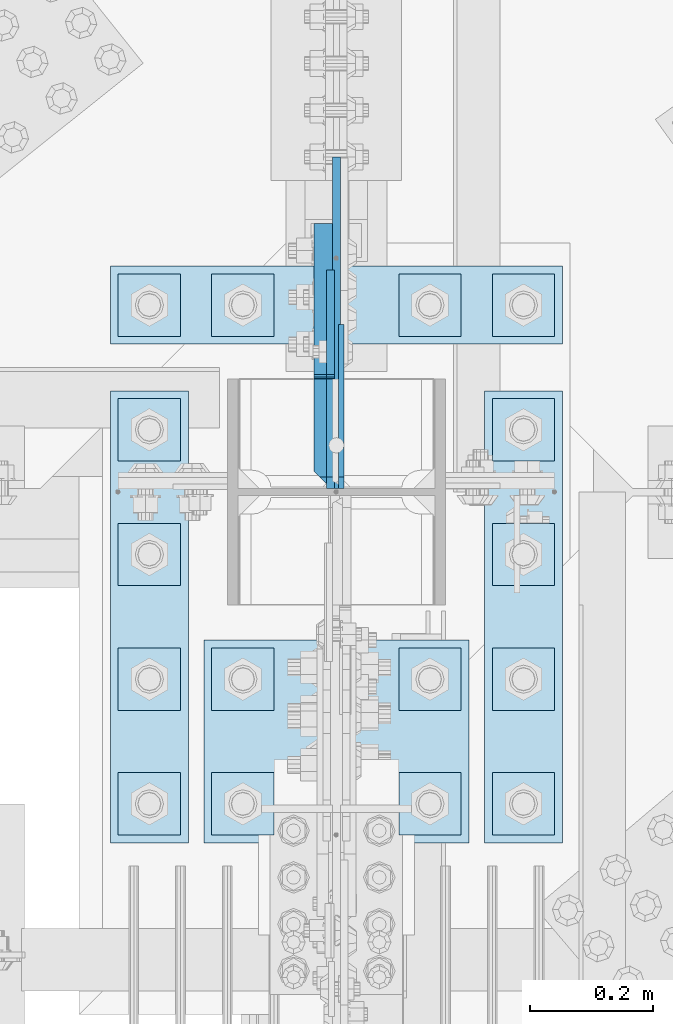
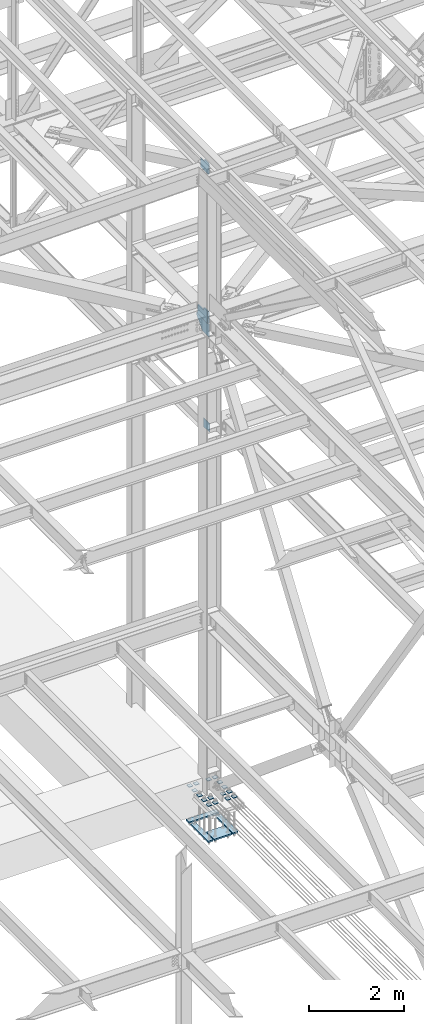
# One storey, part 3201 of 3843: 24 plates, 2 elements without a shape of their own.
"""IFC2X3 building model written with IfcOpenShell, lengths in millimetres."""

from ifc_helpers import new_model, si_unit, frame, origin_with_axes, place, context, subcontext, project, spatial, faceted_brep, material, type_object, element, aggregate, save


model = new_model("IFC2X3")

# Units and contexts
model_context = context("Model", 3, precision=1e-05, world=origin_with_axes())
body_context = subcontext(model_context, "Body", "Model", "MODEL_VIEW")
ifc_project = project(units=[si_unit("LENGTHUNIT", "METRE", prefix="MILLI"), si_unit("AREAUNIT", "SQUARE_METRE"), si_unit("VOLUMEUNIT", "CUBIC_METRE"), si_unit("MASSUNIT", "GRAM", prefix="KILO"), si_unit("TIMEUNIT", "SECOND"), si_unit("PLANEANGLEUNIT", "RADIAN"), si_unit("SOLIDANGLEUNIT", "STERADIAN"), si_unit("THERMODYNAMICTEMPERATUREUNIT", "DEGREE_CELSIUS"), si_unit("LUMINOUSINTENSITYUNIT", "LUMEN")], contexts=[model_context])

# Site, building, storey
site_placement = place(None, origin_with_axes())
site = spatial("IfcSite", under=ifc_project, at=site_placement, CompositionType="ELEMENT")
building_placement = place(site_placement, origin_with_axes())
building = spatial("IfcBuilding", under=site, at=building_placement, Name="Undefined", CompositionType="ELEMENT")
storey_placement = place(building_placement, origin_with_axes())
storey = spatial("IfcBuildingStorey", under=building, at=storey_placement, Name="Undefined", CompositionType="ELEMENT", Elevation=0.0)

# Assembly, plate
assembly_1_placement = place(storey_placement, origin_with_axes())
assembly_1 = element("IfcElementAssembly", 1, at=assembly_1_placement, inside=storey, Name="COLUMN", AssemblyPlace="NOTDEFINED", PredefinedType="RIGID_FRAME")
ifc_material = material(Name="STEEL/A572-50")
plate_type_1 = type_object("IfcPlateType", PredefinedType="NOTDEFINED")
plate_1_placement = place(assembly_1_placement, frame((77020.7375, 25621.45625, 39331.9), z_axis=(0.0, 0.707106781186548, 0.707106781186548), x_axis=(5.70000238222118e-08, 0.707106781186546, -0.707106781186546)))
plate_1 = element("IfcPlate", 2, at=plate_1_placement, type_object=plate_type_1, material=ifc_material, Name="PLATE", context=body_context, shape_type="Brep", body=[
    faceted_brep([(0.0, -4.76249999999709, 0.0), (-134.703841815408, -4.76249999999709, 134.703841815382), (-134.703841815408, 4.76249999999709, 134.703841815382), (0.0, 4.76249999999709, 0.0), (-134.703841815266, -4.76249999999709, 161.644610178599), (-134.703841815266, 4.76249999999709, 161.644610178599), (40.9724185541018, -4.76249999999709, 337.320870548006), (40.9724185541018, 4.76249999999709, 337.320870548006), (202.617028732588, -4.76249999999709, 175.676260369546), (202.617028732588, 4.76249999999709, 175.676260369546), (26.9407683631998, -4.76249999999709, 1.30967237055302e-10), (26.9407683631998, 4.76249999999709, 1.30967237055302e-10)], [[[0, 1, 2, 3]], [[1, 4, 5, 2]], [[4, 6, 7, 5]], [[6, 8, 9, 7]], [[8, 10, 11, 9]], [[10, 0, 3, 11]], [[5, 7, 9, 11, 3, 2]], [[10, 8, 6, 4, 1, 0]]]),
])

# Assembly, plates
assembly_2_placement = place(storey_placement, origin_with_axes())
assembly_2 = element("IfcElementAssembly", 3, at=assembly_2_placement, inside=storey, Name="TEMPLATE", AssemblyPlace="NOTDEFINED", PredefinedType="RIGID_FRAME")
plate_type_2 = type_object("IfcPlateType", PredefinedType="NOTDEFINED")
plate_2_placement = place(assembly_2_placement, frame((77266.8, 25158.7, 30143.45), z_axis=(0.0, -1.0, 0.0), x_axis=(1.0, 0.0, 0.0)))
plate_2 = element("IfcPlate", 4, at=plate_2_placement, type_object=plate_type_2, material=ifc_material, Name="Washer Plate", context=body_context, shape_type="Brep", body=[
    faceted_brep([(0.0, -6.3499999046162, 0.0), (-1.67347025126219e-10, -6.35000000000582, 101.600000000151), (-1.67347025126219e-10, 6.35000000000582, 101.600000000151), (7.27595761418343e-12, 6.3499999046162, 0.0), (101.599998474121, -6.34999999999854, 101.599998474121), (101.599998474121, 6.34999999999854, 101.599998474121), (101.6, -6.34999999999854, 0.0), (101.6, 6.34999999999854, 0.0)], [[[0, 1, 2, 3]], [[1, 4, 5, 2]], [[4, 6, 7, 5]], [[6, 0, 3, 7]], [[5, 7, 3, 2]], [[6, 4, 1, 0]]]),
])
plate_3_placement = place(assembly_2_placement, frame((77266.8, 25361.9, 30143.45), z_axis=(0.0, -1.0, 0.0), x_axis=(1.0, 0.0, 0.0)))
plate_3 = element("IfcPlate", 5, at=plate_3_placement, type_object=plate_type_2, material=ifc_material, Name="Washer Plate", context=body_context, shape_type="Brep", body=[
    faceted_brep([(0.0, -6.3499999046162, 0.0), (-1.67347025126219e-10, -6.35000000000582, 101.600000000151), (-1.67347025126219e-10, 6.35000000000582, 101.600000000151), (7.27595761418343e-12, 6.3499999046162, 0.0), (101.599998474121, -6.34999999999854, 101.599998474121), (101.599998474121, 6.34999999999854, 101.599998474121), (101.6, -6.34999999999854, 0.0), (101.6, 6.34999999999854, 0.0)], [[[0, 1, 2, 3]], [[1, 4, 5, 2]], [[4, 6, 7, 5]], [[6, 0, 3, 7]], [[5, 7, 3, 2]], [[6, 4, 1, 0]]]),
])
plate_4_placement = place(assembly_2_placement, frame((77266.8, 25565.1, 30143.45), z_axis=(0.0, -1.0, 0.0), x_axis=(1.0, 0.0, 0.0)))
plate_4 = element("IfcPlate", 6, at=plate_4_placement, type_object=plate_type_2, material=ifc_material, Name="Washer Plate", context=body_context, shape_type="Brep", body=[
    faceted_brep([(0.0, -6.3499999046162, 0.0), (-1.67347025126219e-10, -6.35000000000582, 101.600000000151), (-1.67347025126219e-10, 6.35000000000582, 101.600000000151), (7.27595761418343e-12, 6.3499999046162, 0.0), (101.599998474121, -6.34999999999854, 101.599998474121), (101.599998474121, 6.34999999999854, 101.599998474121), (101.6, -6.34999999999854, 0.0), (101.6, 6.34999999999854, 0.0)], [[[0, 1, 2, 3]], [[1, 4, 5, 2]], [[4, 6, 7, 5]], [[6, 0, 3, 7]], [[5, 7, 3, 2]], [[6, 4, 1, 0]]]),
])
plate_5_placement = place(assembly_2_placement, frame((77266.8, 25768.3, 30143.45), z_axis=(0.0, -1.0, 0.0), x_axis=(1.0, 0.0, 0.0)))
plate_5 = element("IfcPlate", 7, at=plate_5_placement, type_object=plate_type_2, material=ifc_material, Name="Washer Plate", context=body_context, shape_type="Brep", body=[
    faceted_brep([(0.0, -6.3499999046162, 0.0), (-1.67347025126219e-10, -6.35000000000582, 101.600000000151), (-1.67347025126219e-10, 6.35000000000582, 101.600000000151), (7.27595761418343e-12, 6.3499999046162, 0.0), (101.599998474121, -6.34999999999854, 101.599998474121), (101.599998474121, 6.34999999999854, 101.599998474121), (101.6, -6.34999999999854, 0.0), (101.6, 6.34999999999854, 0.0)], [[[0, 1, 2, 3]], [[1, 4, 5, 2]], [[4, 6, 7, 5]], [[6, 0, 3, 7]], [[5, 7, 3, 2]], [[6, 4, 1, 0]]]),
])
plate_6_placement = place(assembly_2_placement, frame((77266.8, 25971.5, 30143.45), z_axis=(0.0, -1.0, 0.0), x_axis=(1.0, 0.0, 0.0)))
plate_6 = element("IfcPlate", 8, at=plate_6_placement, type_object=plate_type_2, material=ifc_material, Name="Washer Plate", context=body_context, shape_type="Brep", body=[
    faceted_brep([(0.0, -6.3499999046162, 0.0), (-1.67347025126219e-10, -6.35000000000582, 101.600000000151), (-1.67347025126219e-10, 6.35000000000582, 101.600000000151), (7.27595761418343e-12, 6.3499999046162, 0.0), (101.599998474121, -6.34999999999854, 101.599998474121), (101.599998474121, 6.34999999999854, 101.599998474121), (101.6, -6.34999999999854, 0.0), (101.6, 6.34999999999854, 0.0)], [[[0, 1, 2, 3]], [[1, 4, 5, 2]], [[4, 6, 7, 5]], [[6, 0, 3, 7]], [[5, 7, 3, 2]], [[6, 4, 1, 0]]]),
])
plate_7_placement = place(assembly_2_placement, frame((77114.4, 25158.7, 30143.45), z_axis=(0.0, -1.0, 0.0), x_axis=(1.0, 0.0, 0.0)))
plate_7 = element("IfcPlate", 9, at=plate_7_placement, type_object=plate_type_2, material=ifc_material, Name="Washer Plate", context=body_context, shape_type="Brep", body=[
    faceted_brep([(0.0, -6.3499999046162, 0.0), (-1.67347025126219e-10, -6.35000000000582, 101.600000000151), (-1.67347025126219e-10, 6.35000000000582, 101.600000000151), (7.27595761418343e-12, 6.3499999046162, 0.0), (101.599998474121, -6.34999999999854, 101.599998474121), (101.599998474121, 6.34999999999854, 101.599998474121), (101.6, -6.34999999999854, 0.0), (101.6, 6.34999999999854, 0.0)], [[[0, 1, 2, 3]], [[1, 4, 5, 2]], [[4, 6, 7, 5]], [[6, 0, 3, 7]], [[5, 7, 3, 2]], [[6, 4, 1, 0]]]),
])
plate_8_placement = place(assembly_2_placement, frame((77114.4, 25361.9, 30143.45), z_axis=(0.0, -1.0, 0.0), x_axis=(1.0, 0.0, 0.0)))
plate_8 = element("IfcPlate", 10, at=plate_8_placement, type_object=plate_type_2, material=ifc_material, Name="Washer Plate", context=body_context, shape_type="Brep", body=[
    faceted_brep([(0.0, -6.3499999046162, 0.0), (-1.67347025126219e-10, -6.35000000000582, 101.600000000151), (-1.67347025126219e-10, 6.35000000000582, 101.600000000151), (7.27595761418343e-12, 6.3499999046162, 0.0), (101.599998474121, -6.34999999999854, 101.599998474121), (101.599998474121, 6.34999999999854, 101.599998474121), (101.6, -6.34999999999854, 0.0), (101.6, 6.34999999999854, 0.0)], [[[0, 1, 2, 3]], [[1, 4, 5, 2]], [[4, 6, 7, 5]], [[6, 0, 3, 7]], [[5, 7, 3, 2]], [[6, 4, 1, 0]]]),
])
plate_9_placement = place(assembly_2_placement, frame((77114.4, 25971.5, 30143.45), z_axis=(0.0, -1.0, 0.0), x_axis=(1.0, 0.0, 0.0)))
plate_9 = element("IfcPlate", 11, at=plate_9_placement, type_object=plate_type_2, material=ifc_material, Name="Washer Plate", context=body_context, shape_type="Brep", body=[
    faceted_brep([(0.0, -6.3499999046162, 0.0), (-1.67347025126219e-10, -6.35000000000582, 101.600000000151), (-1.67347025126219e-10, 6.35000000000582, 101.600000000151), (7.27595761418343e-12, 6.3499999046162, 0.0), (101.599998474121, -6.34999999999854, 101.599998474121), (101.599998474121, 6.34999999999854, 101.599998474121), (101.6, -6.34999999999854, 0.0), (101.6, 6.34999999999854, 0.0)], [[[0, 1, 2, 3]], [[1, 4, 5, 2]], [[4, 6, 7, 5]], [[6, 0, 3, 7]], [[5, 7, 3, 2]], [[6, 4, 1, 0]]]),
])
plate_10_placement = place(assembly_2_placement, frame((76809.6, 25158.7, 30143.45), z_axis=(0.0, -1.0, 0.0), x_axis=(1.0, 0.0, 0.0)))
plate_10 = element("IfcPlate", 12, at=plate_10_placement, type_object=plate_type_2, material=ifc_material, Name="Washer Plate", context=body_context, shape_type="Brep", body=[
    faceted_brep([(0.0, -6.3499999046162, 0.0), (-1.67347025126219e-10, -6.35000000000582, 101.600000000151), (-1.67347025126219e-10, 6.35000000000582, 101.600000000151), (7.27595761418343e-12, 6.3499999046162, 0.0), (101.599998474121, -6.34999999999854, 101.599998474121), (101.599998474121, 6.34999999999854, 101.599998474121), (101.6, -6.34999999999854, 0.0), (101.6, 6.34999999999854, 0.0)], [[[0, 1, 2, 3]], [[1, 4, 5, 2]], [[4, 6, 7, 5]], [[6, 0, 3, 7]], [[5, 7, 3, 2]], [[6, 4, 1, 0]]]),
])
plate_11_placement = place(assembly_2_placement, frame((76809.6, 25361.9, 30143.45), z_axis=(0.0, -1.0, 0.0), x_axis=(1.0, 0.0, 0.0)))
plate_11 = element("IfcPlate", 13, at=plate_11_placement, type_object=plate_type_2, material=ifc_material, Name="Washer Plate", context=body_context, shape_type="Brep", body=[
    faceted_brep([(0.0, -6.3499999046162, 0.0), (-1.67347025126219e-10, -6.35000000000582, 101.600000000151), (-1.67347025126219e-10, 6.35000000000582, 101.600000000151), (7.27595761418343e-12, 6.3499999046162, 0.0), (101.599998474121, -6.34999999999854, 101.599998474121), (101.599998474121, 6.34999999999854, 101.599998474121), (101.6, -6.34999999999854, 0.0), (101.6, 6.34999999999854, 0.0)], [[[0, 1, 2, 3]], [[1, 4, 5, 2]], [[4, 6, 7, 5]], [[6, 0, 3, 7]], [[5, 7, 3, 2]], [[6, 4, 1, 0]]]),
])
plate_12_placement = place(assembly_2_placement, frame((76809.6, 25971.5, 30143.45), z_axis=(0.0, -1.0, 0.0), x_axis=(1.0, 0.0, 0.0)))
plate_12 = element("IfcPlate", 14, at=plate_12_placement, type_object=plate_type_2, material=ifc_material, Name="Washer Plate", context=body_context, shape_type="Brep", body=[
    faceted_brep([(0.0, -6.3499999046162, 0.0), (-1.67347025126219e-10, -6.35000000000582, 101.600000000151), (-1.67347025126219e-10, 6.35000000000582, 101.600000000151), (7.27595761418343e-12, 6.3499999046162, 0.0), (101.599998474121, -6.34999999999854, 101.599998474121), (101.599998474121, 6.34999999999854, 101.599998474121), (101.6, -6.34999999999854, 0.0), (101.6, 6.34999999999854, 0.0)], [[[0, 1, 2, 3]], [[1, 4, 5, 2]], [[4, 6, 7, 5]], [[6, 0, 3, 7]], [[5, 7, 3, 2]], [[6, 4, 1, 0]]]),
])
plate_13_placement = place(assembly_2_placement, frame((76657.2, 25158.7, 30143.45), z_axis=(0.0, -1.0, 0.0), x_axis=(1.0, 0.0, 0.0)))
plate_13 = element("IfcPlate", 15, at=plate_13_placement, type_object=plate_type_2, material=ifc_material, Name="Washer Plate", context=body_context, shape_type="Brep", body=[
    faceted_brep([(0.0, -6.3499999046162, 0.0), (-1.67347025126219e-10, -6.35000000000582, 101.600000000151), (-1.67347025126219e-10, 6.35000000000582, 101.600000000151), (7.27595761418343e-12, 6.3499999046162, 0.0), (101.599998474121, -6.34999999999854, 101.599998474121), (101.599998474121, 6.34999999999854, 101.599998474121), (101.6, -6.34999999999854, 0.0), (101.6, 6.34999999999854, 0.0)], [[[0, 1, 2, 3]], [[1, 4, 5, 2]], [[4, 6, 7, 5]], [[6, 0, 3, 7]], [[5, 7, 3, 2]], [[6, 4, 1, 0]]]),
])
plate_14_placement = place(assembly_2_placement, frame((76657.2, 25361.9, 30143.45), z_axis=(0.0, -1.0, 0.0), x_axis=(1.0, 0.0, 0.0)))
plate_14 = element("IfcPlate", 16, at=plate_14_placement, type_object=plate_type_2, material=ifc_material, Name="Washer Plate", context=body_context, shape_type="Brep", body=[
    faceted_brep([(0.0, -6.3499999046162, 0.0), (-1.67347025126219e-10, -6.35000000000582, 101.600000000151), (-1.67347025126219e-10, 6.35000000000582, 101.600000000151), (7.27595761418343e-12, 6.3499999046162, 0.0), (101.599998474121, -6.34999999999854, 101.599998474121), (101.599998474121, 6.34999999999854, 101.599998474121), (101.6, -6.34999999999854, 0.0), (101.6, 6.34999999999854, 0.0)], [[[0, 1, 2, 3]], [[1, 4, 5, 2]], [[4, 6, 7, 5]], [[6, 0, 3, 7]], [[5, 7, 3, 2]], [[6, 4, 1, 0]]]),
])
plate_15_placement = place(assembly_2_placement, frame((76657.2, 25565.1, 30143.45), z_axis=(0.0, -1.0, 0.0), x_axis=(1.0, 0.0, 0.0)))
plate_15 = element("IfcPlate", 17, at=plate_15_placement, type_object=plate_type_2, material=ifc_material, Name="Washer Plate", context=body_context, shape_type="Brep", body=[
    faceted_brep([(0.0, -6.3499999046162, 0.0), (-1.67347025126219e-10, -6.35000000000582, 101.600000000151), (-1.67347025126219e-10, 6.35000000000582, 101.600000000151), (7.27595761418343e-12, 6.3499999046162, 0.0), (101.599998474121, -6.34999999999854, 101.599998474121), (101.599998474121, 6.34999999999854, 101.599998474121), (101.6, -6.34999999999854, 0.0), (101.6, 6.34999999999854, 0.0)], [[[0, 1, 2, 3]], [[1, 4, 5, 2]], [[4, 6, 7, 5]], [[6, 0, 3, 7]], [[5, 7, 3, 2]], [[6, 4, 1, 0]]]),
])
plate_16_placement = place(assembly_2_placement, frame((76657.2, 25768.3, 30143.45), z_axis=(0.0, -1.0, 0.0), x_axis=(1.0, 0.0, 0.0)))
plate_16 = element("IfcPlate", 18, at=plate_16_placement, type_object=plate_type_2, material=ifc_material, Name="Washer Plate", context=body_context, shape_type="Brep", body=[
    faceted_brep([(0.0, -6.3499999046162, 0.0), (-1.67347025126219e-10, -6.35000000000582, 101.600000000151), (-1.67347025126219e-10, 6.35000000000582, 101.600000000151), (7.27595761418343e-12, 6.3499999046162, 0.0), (101.599998474121, -6.34999999999854, 101.599998474121), (101.599998474121, 6.34999999999854, 101.599998474121), (101.6, -6.34999999999854, 0.0), (101.6, 6.34999999999854, 0.0)], [[[0, 1, 2, 3]], [[1, 4, 5, 2]], [[4, 6, 7, 5]], [[6, 0, 3, 7]], [[5, 7, 3, 2]], [[6, 4, 1, 0]]]),
])
plate_17_placement = place(assembly_2_placement, frame((76657.2, 25971.5, 30143.45), z_axis=(0.0, -1.0, 0.0), x_axis=(1.0, 0.0, 0.0)))
plate_17 = element("IfcPlate", 19, at=plate_17_placement, type_object=plate_type_2, material=ifc_material, Name="Washer Plate", context=body_context, shape_type="Brep", body=[
    faceted_brep([(0.0, -6.3499999046162, 0.0), (-1.67347025126219e-10, -6.35000000000582, 101.600000000151), (-1.67347025126219e-10, 6.35000000000582, 101.600000000151), (7.27595761418343e-12, 6.3499999046162, 0.0), (101.599998474121, -6.34999999999854, 101.599998474121), (101.599998474121, 6.34999999999854, 101.599998474121), (101.6, -6.34999999999854, 0.0), (101.6, 6.34999999999854, 0.0)], [[[0, 1, 2, 3]], [[1, 4, 5, 2]], [[4, 6, 7, 5]], [[6, 0, 3, 7]], [[5, 7, 3, 2]], [[6, 4, 1, 0]]]),
])

# Plate
plate_type_3 = type_object("IfcPlateType", PredefinedType="NOTDEFINED")
plate_18_placement = place(assembly_1_placement, frame((77012.8, 25621.4562499996, 42092.5624999998), z_axis=(0.0, 1.0, 0.0), x_axis=(0.0, 0.0, -1.0)))
plate_18 = element("IfcPlate", 20, at=plate_18_placement, type_object=plate_type_3, material=ifc_material, Name="PLATE", context=body_context, shape_type="Brep", body=[
    faceted_brep([(19.0499992370605, -6.34999999999854, 0.0), (0.0, -6.34999999999854, 19.0499992370605), (0.0, 6.34999999999854, 19.0499992370605), (19.0499992370605, 6.34999999999854, 0.0), (0.0, -6.35000000000582, 540.37130841432), (51.2388908941648, -6.35000000000582, 540.37130841432), (51.2388908941648, 6.35000000000582, 540.37130841432), (0.0, 6.35000000000582, 540.37130841432), (323.518849143686, -6.35000000000582, 292.362207098176), (323.518849143686, 6.35000000000582, 292.362207098176), (323.518849143686, -6.35000000000582, 0.0), (323.518849143686, 6.35000000000582, 0.0)], [[[0, 1, 2, 3]], [[4, 5, 6, 7]], [[5, 8, 9, 6]], [[8, 10, 11, 9]], [[11, 10, 0, 3]], [[7, 6, 9, 11, 3, 2]], [[4, 7, 2, 1]], [[10, 8, 5, 4, 1, 0]]]),
])

plate_type_4 = type_object("IfcPlateType", PredefinedType="NOTDEFINED")
plate_19_placement = place(assembly_1_placement, frame((76992.1625, 25621.45625, 42143.3625), z_axis=(0.0, 0.707106781186548, 0.707106781186548), x_axis=(5.70000238222118e-08, 0.707106781186546, -0.707106781186546)))
plate_19 = element("IfcPlate", 21, at=plate_19_placement, type_object=plate_type_4, material=ifc_material, Name="PLATE", context=body_context, shape_type="Brep", body=[
    faceted_brep([(-187.463022763639, 15.875, 227.873822833804), (33.6757842166026, 15.875, 6.73501585351914), (26.9407683630798, 6.35008257334994, 0.0), (1.81898940354586e-12, -12.7002507628931, 0.0), (-194.198038617162, -12.7002507628931, 194.1980386172), (-194.198038617162, 6.35008257334994, 221.138806980285), (0.0, -15.875, 0.0), (-194.198038617162, -15.875, 194.1980386172), (-194.198038617162, -15.875, 221.138806980285), (-81.3835710967596, -15.875, 333.953274500665), (-81.3835710967596, 15.875, 333.953274500665), (-37.6048223719172, -15.875, 290.174525775801), (-37.6048223719172, 15.875, 290.174525775801), (-33.4846459037744, -15.875, 287.421511875335), (-33.4846459037744, 15.875, 287.421511875335), (-28.6245663857389, -15.875, 286.454781952751), (-28.6245663857389, 15.875, 286.454781952751), (-23.7644868676998, -15.875, 287.421511875335), (-23.7644868676998, 15.875, 287.421511875335), (-19.6443103995607, -15.875, 290.174525775801), (-19.6443103995607, 15.875, 290.174525775801), (150.980556034798, -15.875, 460.79939221013), (150.980556034798, 15.875, 460.79939221013), (312.625166213247, -15.875, 299.154782031641), (312.625166213247, 15.875, 299.154782031641), (139.755235613762, -15.875, 126.284851432189), (139.755235613762, 15.875, 126.284851432189), (137.69047524009, -15.875, 123.194719158433), (137.69047524009, 15.875, 123.194719158433), (136.965427816298, -15.875, 119.549659611148), (136.965427816298, 15.875, 119.549659611148), (137.690475240086, -15.875, 115.904600063863), (137.690475240086, 15.875, 115.904600063863), (139.755235883486, -15.875, 112.814467520366), (139.755235883486, 15.875, 112.814467520366), (26.9407683630798, -15.875, 0.0)], [[[0, 1, 2, 3, 4, 5]], [[6, 7, 4, 3]], [[7, 8, 5, 4]], [[8, 9, 10, 0, 5]], [[9, 11, 12, 10]], [[11, 13, 14, 12]], [[13, 15, 16, 14]], [[15, 17, 18, 16]], [[17, 19, 20, 18]], [[19, 21, 22, 20]], [[21, 23, 24, 22]], [[23, 25, 26, 24]], [[25, 27, 28, 26]], [[27, 29, 30, 28]], [[29, 31, 32, 30]], [[31, 33, 34, 32]], [[34, 33, 35, 2, 1]], [[35, 6, 3, 2]], [[10, 12, 14, 16, 18, 20, 22, 24, 26, 28, 30, 32, 34, 1, 0]], [[35, 33, 31, 29, 27, 25, 23, 21, 19, 17, 15, 13, 11, 9, 8, 7, 6]]]),
])

plate_type_5 = type_object("IfcPlateType", PredefinedType="NOTDEFINED")
plate_20_placement = place(assembly_1_placement, frame((77003.2750001572, 25621.45625, 45972.2205507418), z_axis=(0.0, 0.707106781186548, 0.707106781186548), x_axis=(5.70000238222118e-08, 0.707106781186546, -0.707106781186546)))
plate_20 = element("IfcPlate", 22, at=plate_20_placement, type_object=plate_type_5, material=ifc_material, Name="PLATE", context=body_context, shape_type="Brep", body=[
    faceted_brep([(0.0, -6.3499999046162, 0.0), (-186.340314511304, -6.35000000000582, 186.340314511268), (-186.340314511304, 6.35000000000582, 186.340314511268), (7.27595761418343e-12, 6.3499999046162, 0.0), (-186.340314511177, -6.35000000000582, 213.281082874484), (-186.340314511177, 6.35000000000582, 213.281082874484), (-73.5258469896398, -6.35000000000582, 326.095550396043), (-73.5258469896398, 6.35000000000582, 326.095550396043), (-39.8498864009416, -6.35000000000582, 292.419589807352), (-39.8498864009416, 6.35000000000582, 292.419589807352), (-35.7297099327989, -6.35000000000582, 289.666575906886), (-35.7297099327989, 6.35000000000582, 289.666575906886), (-30.8696304147634, -6.35000000000582, 288.699845984302), (-30.8696304147634, 6.35000000000582, 288.699845984302), (-26.0095508967242, -6.35000000000582, 289.666575906886), (-26.0095508967242, 6.35000000000582, 289.666575906886), (-21.8893744285815, -6.35000000000582, 292.419589807352), (-21.8893744285815, 6.35000000000582, 292.419589807352), (94.853955280887, -6.35000000000582, 409.16291951685), (94.853955280887, 6.35000000000582, 409.16291951685), (265.478821582976, -6.35000000000582, 238.538053219985), (265.478821582976, 6.35000000000582, 238.538053219985), (26.9407683632217, -6.34999999999854, 1.30967237055302e-10), (26.9407683632217, 6.34999999999854, 1.30967237055302e-10)], [[[0, 1, 2, 3]], [[1, 4, 5, 2]], [[4, 6, 7, 5]], [[6, 8, 9, 7]], [[8, 10, 11, 9]], [[10, 12, 13, 11]], [[12, 14, 15, 13]], [[14, 16, 17, 15]], [[16, 18, 19, 17]], [[18, 20, 21, 19]], [[20, 22, 23, 21]], [[22, 0, 3, 23]], [[5, 7, 9, 11, 13, 15, 17, 19, 21, 23, 3, 2]], [[22, 20, 18, 16, 14, 12, 10, 8, 6, 4, 1, 0]]]),
])

aggregate(assembly_1, [plate_18, plate_19, plate_1, plate_20])

plate_type_6 = type_object("IfcPlateType", PredefinedType="NOTDEFINED")
plate_21_placement = place(assembly_2_placement, frame((76644.5, 25984.2, 29241.75), z_axis=(0.0, -1.0, 0.0), x_axis=(1.0, 0.0, 0.0)))
plate_21 = element("IfcPlate", 23, at=plate_21_placement, type_object=plate_type_6, material=ifc_material, Name="PLATE", context=body_context, shape_type="Brep", body=[
    faceted_brep([(0.0, -19.0500000000029, 0.0), (0.0, -19.0499999999993, 127.0), (0.0, 19.0499999999993, 127.0), (0.0, 19.0500000000029, 0.0), (736.599975585938, -19.0499999999993, 127.0), (736.599975585938, 19.0499999999993, 127.0), (736.599975585938, -19.0499999999993, 0.0), (736.599975585938, 19.0499999999993, 0.0)], [[[0, 1, 2, 3]], [[1, 4, 5, 2]], [[4, 6, 7, 5]], [[6, 0, 3, 7]], [[5, 7, 3, 2]], [[6, 4, 1, 0]]]),
])

plate_22_placement = place(assembly_2_placement, frame((76644.5, 25781.0, 29241.75), z_axis=(0.0, -1.0, 0.0), x_axis=(1.0, 0.0, 0.0)))
plate_22 = element("IfcPlate", 24, at=plate_22_placement, type_object=plate_type_6, material=ifc_material, Name="PLATE", context=body_context, shape_type="Brep", body=[
    faceted_brep([(0.0, -19.0500000000029, 0.0), (0.0, -19.0499999999993, 736.600036621094), (0.0, 19.0499999999993, 736.600036621094), (0.0, 19.0500000000029, 0.0), (127.0, -19.0499999999993, 736.600036621094), (127.0, 19.0499999999993, 736.600036621094), (127.0, -19.0499999999993, 0.0), (127.0, 19.0499999999993, 0.0)], [[[0, 1, 2, 3]], [[1, 4, 5, 2]], [[4, 6, 7, 5]], [[6, 0, 3, 7]], [[5, 7, 3, 2]], [[6, 4, 1, 0]]]),
])

plate_23_placement = place(assembly_2_placement, frame((77254.1, 25781.0, 29241.75), z_axis=(0.0, -1.0, 0.0), x_axis=(1.0, 0.0, 0.0)))
plate_23 = element("IfcPlate", 25, at=plate_23_placement, type_object=plate_type_6, material=ifc_material, Name="PLATE", context=body_context, shape_type="Brep", body=[
    faceted_brep([(0.0, -19.0500000000029, 0.0), (0.0, -19.0499999999993, 736.600036621094), (0.0, 19.0499999999993, 736.600036621094), (0.0, 19.0500000000029, 0.0), (127.0, -19.0499999999993, 736.600036621094), (127.0, 19.0499999999993, 736.600036621094), (127.0, -19.0499999999993, 0.0), (127.0, 19.0499999999993, 0.0)], [[[0, 1, 2, 3]], [[1, 4, 5, 2]], [[4, 6, 7, 5]], [[6, 0, 3, 7]], [[5, 7, 3, 2]], [[6, 4, 1, 0]]]),
])

plate_type_7 = type_object("IfcPlateType", PredefinedType="NOTDEFINED")
plate_24_placement = place(assembly_2_placement, frame((76796.9, 25374.6, 29241.75), z_axis=(0.0, -1.0, 0.0), x_axis=(1.0, 0.0, 0.0)))
plate_24 = element("IfcPlate", 26, at=plate_24_placement, type_object=plate_type_7, material=ifc_material, Name="PLATE", context=body_context, shape_type="Brep", body=[
    faceted_brep([(0.0, -19.0500000000029, 0.0), (0.0, -19.0499999999993, 330.200012207031), (0.0, 19.0499999999993, 330.200012207031), (0.0, 19.0500000000029, 0.0), (431.799957275391, -19.0499999999993, 330.200012207031), (431.799957275391, 19.0499999999993, 330.200012207031), (431.799957275391, -19.0499999999993, 0.0), (431.799957275391, 19.0499999999993, 0.0)], [[[0, 1, 2, 3]], [[1, 4, 5, 2]], [[4, 6, 7, 5]], [[6, 0, 3, 7]], [[5, 7, 3, 2]], [[6, 4, 1, 0]]]),
])

aggregate(assembly_2, [plate_2, plate_3, plate_4, plate_5, plate_6, plate_7, plate_8, plate_9, plate_10, plate_11, plate_12, plate_13, plate_14, plate_15, plate_16, plate_17, plate_21, plate_24, plate_22, plate_23])

save(model, "model.ifc")
